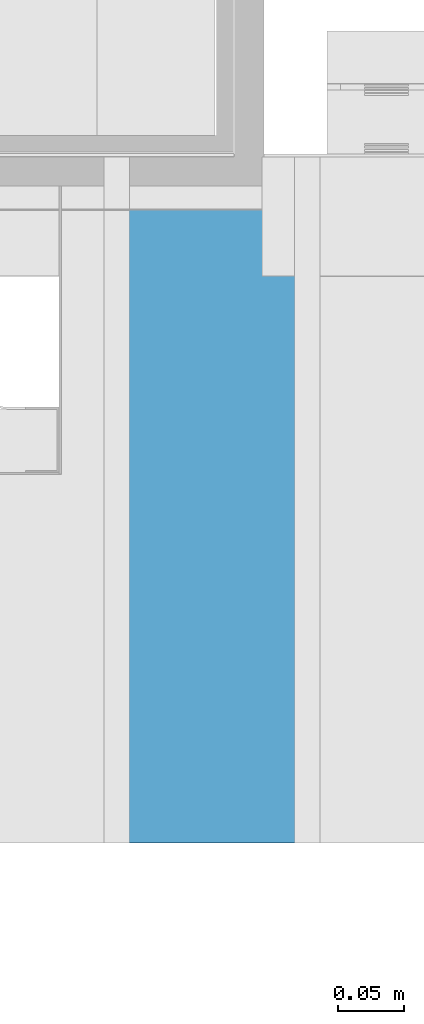
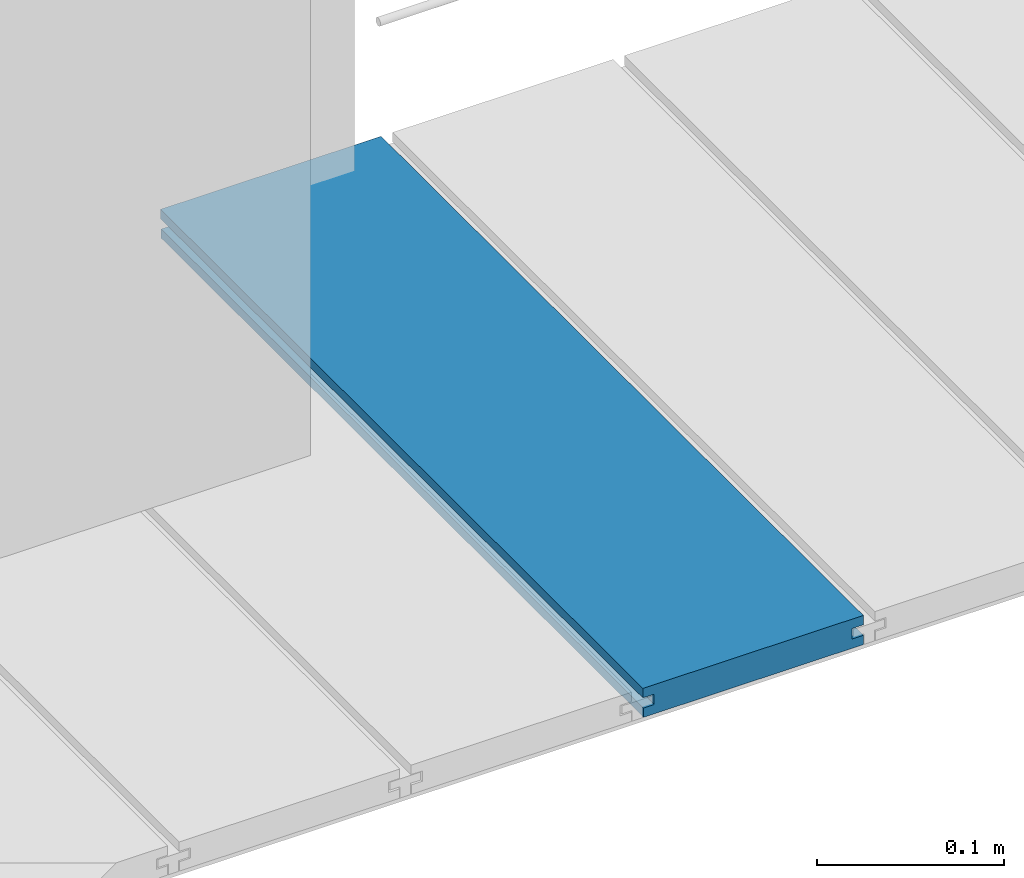
# One storey, part 19 of 33: 1 wall.
"""IFC4 building model written with IfcOpenShell, lengths in feet."""

from ifc_helpers import new_model, entity, si_unit, converted_unit, derived_unit, direction, frame, origin, place, context, subcontext, project, spatial, material, type_object, element, save


model = new_model("IFC4")

# Units and contexts
model_context = context("Model", 3, precision=0.0001, world=origin(), true_north=direction((6.12303176911189e-17, 1.0)))
body_context = subcontext(model_context, "Body", "Model", "MODEL_VIEW")
ifc_project = project(units=[converted_unit("LENGTHUNIT", "FOOT", entity("IfcRatioMeasure", 0.3048), si_unit("LENGTHUNIT", "METRE"), dimensions=[1, 0, 0, 0, 0, 0, 0]), converted_unit("AREAUNIT", "SQUARE FOOT", entity("IfcRatioMeasure", 0.09290304), si_unit("AREAUNIT", "SQUARE_METRE"), dimensions=[2, 0, 0, 0, 0, 0, 0]), converted_unit("VOLUMEUNIT", "CUBIC FOOT", entity("IfcRatioMeasure", 0.028316846592), si_unit("VOLUMEUNIT", "CUBIC_METRE"), dimensions=[3, 0, 0, 0, 0, 0, 0]), converted_unit("PLANEANGLEUNIT", "DEGREE", entity("IfcRatioMeasure", 0.0174532925199433), si_unit("PLANEANGLEUNIT", "RADIAN"), dimensions=[0, 0, 0, 0, 0, 0, 0]), si_unit("MASSUNIT", "GRAM", prefix="KILO"), derived_unit("MASSDENSITYUNIT", [(si_unit("MASSUNIT", "GRAM", prefix="KILO"), 1), (si_unit("LENGTHUNIT", "METRE"), -3)]), derived_unit("MOMENTOFINERTIAUNIT", [(si_unit("LENGTHUNIT", "METRE"), 4)]), si_unit("TIMEUNIT", "SECOND"), si_unit("FREQUENCYUNIT", "HERTZ"), si_unit("THERMODYNAMICTEMPERATUREUNIT", "DEGREE_CELSIUS"), derived_unit("THERMALTRANSMITTANCEUNIT", [(si_unit("MASSUNIT", "GRAM", prefix="KILO"), 1), (si_unit("THERMODYNAMICTEMPERATUREUNIT", "KELVIN"), -1), (si_unit("TIMEUNIT", "SECOND"), -3)]), derived_unit("VOLUMETRICFLOWRATEUNIT", [(si_unit("LENGTHUNIT", "METRE"), 3), (si_unit("TIMEUNIT", "SECOND"), -1)]), si_unit("ELECTRICCURRENTUNIT", "AMPERE"), si_unit("ELECTRICVOLTAGEUNIT", "VOLT"), si_unit("POWERUNIT", "WATT"), si_unit("FORCEUNIT", "NEWTON"), si_unit("ILLUMINANCEUNIT", "LUX"), si_unit("LUMINOUSFLUXUNIT", "LUMEN"), si_unit("LUMINOUSINTENSITYUNIT", "CANDELA"), derived_unit("USERDEFINED", [(si_unit("MASSUNIT", "GRAM", prefix="KILO"), -1), (si_unit("LENGTHUNIT", "METRE"), -2), (si_unit("TIMEUNIT", "SECOND"), 3), (si_unit("LUMINOUSFLUXUNIT", "LUMEN"), 1)]), derived_unit("LINEARVELOCITYUNIT", [(si_unit("LENGTHUNIT", "METRE"), 1), (si_unit("TIMEUNIT", "SECOND"), -1)]), si_unit("PRESSUREUNIT", "PASCAL"), derived_unit("USERDEFINED", [(si_unit("LENGTHUNIT", "METRE"), -2), (si_unit("MASSUNIT", "GRAM", prefix="KILO"), 1), (si_unit("TIMEUNIT", "SECOND"), -2)]), derived_unit("LINEARFORCEUNIT", [(si_unit("MASSUNIT", "GRAM", prefix="KILO"), 1), (si_unit("LENGTHUNIT", "METRE"), 1), (si_unit("TIMEUNIT", "SECOND"), -2), (si_unit("LENGTHUNIT", "METRE"), -1)]), derived_unit("PLANARFORCEUNIT", [(si_unit("MASSUNIT", "GRAM", prefix="KILO"), 1), (si_unit("LENGTHUNIT", "METRE"), 1), (si_unit("TIMEUNIT", "SECOND"), -2), (si_unit("LENGTHUNIT", "METRE"), -2)])], contexts=[model_context])

# Site, building, storey
site_placement = place(None, origin())
site = spatial("IfcSite", under=ifc_project, at=site_placement, CompositionType="ELEMENT")
building_placement = place(site_placement, origin())
building = spatial("IfcBuilding", under=site, at=building_placement, CompositionType="ELEMENT")
storey_placement = place(building_placement, frame((0.0, 0.0, 10.0)))
storey = spatial("IfcBuildingStorey", under=building, at=storey_placement, Name="2ND FLOOR", CompositionType="ELEMENT", Elevation=10.0000000000002)

# Wall
ifc_material = material(Name="COMPOSITE DECKING W/ HIDDEN FASTENERS", Category="Materials")
wall_type = type_object("IfcWallType", Name="Generic Models 661:Generic Models 1", PredefinedType="NOTDEFINED", material=ifc_material)
wall_placement = place(storey_placement, frame((1492.00118914657, 3.0461139299927, 0.682902157150133), z_axis=(0.0, 0.0, 1.0), x_axis=(0.0, 1.0, 0.0)))
cartesian_point_1 = entity("IfcCartesianPoint", [1.69226081335874, -0.446740923891412, 0.0])
vertex_point_1 = entity("IfcVertexPoint", cartesian_point_1)
cartesian_point_2 = entity("IfcCartesianPoint", [1.69226081335875, -0.00132475379450625, 0.0])
vertex_point_2 = entity("IfcVertexPoint", cartesian_point_2)
ifc_direction_1 = entity("IfcDirection", [0.0, 1.0, 0.0])
edge_curve_1 = entity("IfcEdgeCurve", vertex_point_1, vertex_point_2, entity("IfcTrimmedCurve", entity("IfcLine", cartesian_point_1, entity("IfcVector", ifc_direction_1, 1.0)), [cartesian_point_1], [cartesian_point_2], True, "CARTESIAN"), True)
cartesian_point_3 = entity("IfcCartesianPoint", [1.69226081335875, -0.00132475379450625, 0.0198779960861479])
vertex_point_3 = entity("IfcVertexPoint", cartesian_point_3)
ifc_direction_2 = entity("IfcDirection", [0.0, 0.0, 1.0])
edge_curve_2 = entity("IfcEdgeCurve", vertex_point_2, vertex_point_3, entity("IfcTrimmedCurve", entity("IfcLine", cartesian_point_2, entity("IfcVector", ifc_direction_2, 1.0)), [cartesian_point_2], [cartesian_point_3], True, "CARTESIAN"), True)
cartesian_point_4 = entity("IfcCartesianPoint", [1.69226081335875, -0.0228400010807945, 0.0198779960861479])
vertex_point_4 = entity("IfcVertexPoint", cartesian_point_4)
ifc_direction_3 = entity("IfcDirection", [0.0, -1.0, 0.0])
edge_curve_3 = entity("IfcEdgeCurve", vertex_point_3, vertex_point_4, entity("IfcTrimmedCurve", entity("IfcLine", cartesian_point_3, entity("IfcVector", ifc_direction_3, 1.0)), [cartesian_point_3], [cartesian_point_4], True, "CARTESIAN"), True)
cartesian_point_5 = entity("IfcCartesianPoint", [1.69226081335875, -0.0228400010807945, 0.0422987663426522])
vertex_point_5 = entity("IfcVertexPoint", cartesian_point_5)
edge_curve_4 = entity("IfcEdgeCurve", vertex_point_4, vertex_point_5, entity("IfcTrimmedCurve", entity("IfcLine", cartesian_point_4, entity("IfcVector", ifc_direction_2, 1.0)), [cartesian_point_4], [cartesian_point_5], True, "CARTESIAN"), True)
cartesian_point_6 = entity("IfcCartesianPoint", [1.69226081335875, 0.0, 0.0422987663426522])
vertex_point_6 = entity("IfcVertexPoint", cartesian_point_6)
edge_curve_5 = entity("IfcEdgeCurve", vertex_point_5, vertex_point_6, entity("IfcTrimmedCurve", entity("IfcLine", cartesian_point_5, entity("IfcVector", ifc_direction_1, 1.0)), [cartesian_point_5], [cartesian_point_6], True, "CARTESIAN"), True)
cartesian_point_7 = entity("IfcCartesianPoint", [1.69226081335875, 0.0, 0.0625000000000551])
vertex_point_7 = entity("IfcVertexPoint", cartesian_point_7)
edge_curve_6 = entity("IfcEdgeCurve", vertex_point_6, vertex_point_7, entity("IfcTrimmedCurve", entity("IfcLine", cartesian_point_6, entity("IfcVector", ifc_direction_2, 1.0)), [cartesian_point_6], [cartesian_point_7], True, "CARTESIAN"), True)
cartesian_point_8 = entity("IfcCartesianPoint", [1.69226081335874, -0.446740923891639, 0.0625])
vertex_point_8 = entity("IfcVertexPoint", cartesian_point_8)
edge_curve_7 = entity("IfcEdgeCurve", vertex_point_7, vertex_point_8, entity("IfcTrimmedCurve", entity("IfcLine", cartesian_point_7, entity("IfcVector", ifc_direction_3, 1.0)), [cartesian_point_7], [cartesian_point_8], True, "CARTESIAN"), True)
cartesian_point_9 = entity("IfcCartesianPoint", [1.69226081335874, -0.446740923891639, 0.0422987663426522])
vertex_point_9 = entity("IfcVertexPoint", cartesian_point_9)
ifc_direction_4 = entity("IfcDirection", [0.0, 0.0, -1.0])
edge_curve_8 = entity("IfcEdgeCurve", vertex_point_8, vertex_point_9, entity("IfcTrimmedCurve", entity("IfcLine", cartesian_point_8, entity("IfcVector", ifc_direction_4, 1.0)), [cartesian_point_8], [cartesian_point_9], True, "CARTESIAN"), True)
cartesian_point_10 = entity("IfcCartesianPoint", [1.69226081335874, -0.423900922810617, 0.0422987663426522])
vertex_point_10 = entity("IfcVertexPoint", cartesian_point_10)
edge_curve_9 = entity("IfcEdgeCurve", vertex_point_9, vertex_point_10, entity("IfcTrimmedCurve", entity("IfcLine", cartesian_point_9, entity("IfcVector", ifc_direction_1, 1.0)), [cartesian_point_9], [cartesian_point_10], True, "CARTESIAN"), True)
cartesian_point_11 = entity("IfcCartesianPoint", [1.69226081335874, -0.423900922810617, 0.0198779960861479])
vertex_point_11 = entity("IfcVertexPoint", cartesian_point_11)
edge_curve_10 = entity("IfcEdgeCurve", vertex_point_10, vertex_point_11, entity("IfcTrimmedCurve", entity("IfcLine", cartesian_point_10, entity("IfcVector", ifc_direction_4, 1.0)), [cartesian_point_10], [cartesian_point_11], True, "CARTESIAN"), True)
cartesian_point_12 = entity("IfcCartesianPoint", [1.69226081335874, -0.446740923891412, 0.0198779960861479])
vertex_point_12 = entity("IfcVertexPoint", cartesian_point_12)
edge_curve_11 = entity("IfcEdgeCurve", vertex_point_11, vertex_point_12, entity("IfcTrimmedCurve", entity("IfcLine", cartesian_point_11, entity("IfcVector", ifc_direction_3, 1.0)), [cartesian_point_11], [cartesian_point_12], True, "CARTESIAN"), True)
edge_curve_12 = entity("IfcEdgeCurve", vertex_point_12, vertex_point_1, entity("IfcTrimmedCurve", entity("IfcLine", cartesian_point_12, entity("IfcVector", ifc_direction_4, 1.0)), [cartesian_point_12], [cartesian_point_1], True, "CARTESIAN"), True)
ifc_direction_5 = entity("IfcDirection", [1.0, 0.0, 0.0])
cartesian_point_13 = entity("IfcCartesianPoint", [0.0, -0.446740923891412, 0.0])
vertex_point_13 = entity("IfcVertexPoint", cartesian_point_13)
cartesian_point_14 = entity("IfcCartesianPoint", [0.0, -0.446740923891412, 0.0198779960861479])
vertex_point_14 = entity("IfcVertexPoint", cartesian_point_14)
edge_curve_13 = entity("IfcEdgeCurve", vertex_point_13, vertex_point_14, entity("IfcTrimmedCurve", entity("IfcLine", cartesian_point_13, entity("IfcVector", ifc_direction_2, 1.0)), [cartesian_point_13], [cartesian_point_14], True, "CARTESIAN"), True)
cartesian_point_15 = entity("IfcCartesianPoint", [0.0, -0.423900922810617, 0.0198779960861479])
vertex_point_15 = entity("IfcVertexPoint", cartesian_point_15)
edge_curve_14 = entity("IfcEdgeCurve", vertex_point_14, vertex_point_15, entity("IfcTrimmedCurve", entity("IfcLine", cartesian_point_14, entity("IfcVector", ifc_direction_1, 1.0)), [cartesian_point_14], [cartesian_point_15], True, "CARTESIAN"), True)
cartesian_point_16 = entity("IfcCartesianPoint", [0.0, -0.423900922810617, 0.0422987663426522])
vertex_point_16 = entity("IfcVertexPoint", cartesian_point_16)
edge_curve_15 = entity("IfcEdgeCurve", vertex_point_15, vertex_point_16, entity("IfcTrimmedCurve", entity("IfcLine", cartesian_point_15, entity("IfcVector", ifc_direction_2, 1.0)), [cartesian_point_15], [cartesian_point_16], True, "CARTESIAN"), True)
cartesian_point_17 = entity("IfcCartesianPoint", [0.0, -0.446740923891639, 0.0422987663426522])
vertex_point_17 = entity("IfcVertexPoint", cartesian_point_17)
edge_curve_16 = entity("IfcEdgeCurve", vertex_point_16, vertex_point_17, entity("IfcTrimmedCurve", entity("IfcLine", cartesian_point_16, entity("IfcVector", ifc_direction_3, 1.0)), [cartesian_point_16], [cartesian_point_17], True, "CARTESIAN"), True)
cartesian_point_18 = entity("IfcCartesianPoint", [0.0, -0.446740923891639, 0.0625])
vertex_point_18 = entity("IfcVertexPoint", cartesian_point_18)
edge_curve_17 = entity("IfcEdgeCurve", vertex_point_17, vertex_point_18, entity("IfcTrimmedCurve", entity("IfcLine", cartesian_point_17, entity("IfcVector", ifc_direction_2, 1.0)), [cartesian_point_17], [cartesian_point_18], True, "CARTESIAN"), True)
cartesian_point_19 = entity("IfcCartesianPoint", [0.0, 0.0, 0.0625000000000551])
vertex_point_19 = entity("IfcVertexPoint", cartesian_point_19)
edge_curve_18 = entity("IfcEdgeCurve", vertex_point_18, vertex_point_19, entity("IfcTrimmedCurve", entity("IfcLine", cartesian_point_18, entity("IfcVector", ifc_direction_1, 1.0)), [cartesian_point_18], [cartesian_point_19], True, "CARTESIAN"), True)
cartesian_point_20 = entity("IfcCartesianPoint", [0.0, 0.0, 0.0422987663426522])
vertex_point_20 = entity("IfcVertexPoint", cartesian_point_20)
edge_curve_19 = entity("IfcEdgeCurve", vertex_point_19, vertex_point_20, entity("IfcTrimmedCurve", entity("IfcLine", cartesian_point_19, entity("IfcVector", ifc_direction_4, 1.0)), [cartesian_point_19], [cartesian_point_20], True, "CARTESIAN"), True)
cartesian_point_21 = entity("IfcCartesianPoint", [0.0, -0.0228400010807945, 0.0422987663426522])
vertex_point_21 = entity("IfcVertexPoint", cartesian_point_21)
edge_curve_20 = entity("IfcEdgeCurve", vertex_point_20, vertex_point_21, entity("IfcTrimmedCurve", entity("IfcLine", cartesian_point_20, entity("IfcVector", ifc_direction_3, 1.0)), [cartesian_point_20], [cartesian_point_21], True, "CARTESIAN"), True)
cartesian_point_22 = entity("IfcCartesianPoint", [0.0, -0.0228400010807945, 0.0198779960861479])
vertex_point_22 = entity("IfcVertexPoint", cartesian_point_22)
edge_curve_21 = entity("IfcEdgeCurve", vertex_point_21, vertex_point_22, entity("IfcTrimmedCurve", entity("IfcLine", cartesian_point_21, entity("IfcVector", ifc_direction_4, 1.0)), [cartesian_point_21], [cartesian_point_22], True, "CARTESIAN"), True)
cartesian_point_23 = entity("IfcCartesianPoint", [0.0, -0.00132475379450625, 0.0198779960861479])
vertex_point_23 = entity("IfcVertexPoint", cartesian_point_23)
edge_curve_22 = entity("IfcEdgeCurve", vertex_point_22, vertex_point_23, entity("IfcTrimmedCurve", entity("IfcLine", cartesian_point_22, entity("IfcVector", ifc_direction_1, 1.0)), [cartesian_point_22], [cartesian_point_23], True, "CARTESIAN"), True)
cartesian_point_24 = entity("IfcCartesianPoint", [0.0, -0.00132475379450625, 0.0])
vertex_point_24 = entity("IfcVertexPoint", cartesian_point_24)
edge_curve_23 = entity("IfcEdgeCurve", vertex_point_23, vertex_point_24, entity("IfcTrimmedCurve", entity("IfcLine", cartesian_point_23, entity("IfcVector", ifc_direction_4, 1.0)), [cartesian_point_23], [cartesian_point_24], True, "CARTESIAN"), True)
edge_curve_24 = entity("IfcEdgeCurve", vertex_point_24, vertex_point_13, entity("IfcTrimmedCurve", entity("IfcLine", cartesian_point_24, entity("IfcVector", ifc_direction_3, 1.0)), [cartesian_point_24], [cartesian_point_13], True, "CARTESIAN"), True)
ifc_direction_6 = entity("IfcDirection", [-1.0, 0.0, 0.0])
edge_curve_25 = entity("IfcEdgeCurve", vertex_point_13, vertex_point_1, entity("IfcTrimmedCurve", entity("IfcLine", cartesian_point_13, entity("IfcVector", ifc_direction_5, 1.0)), [cartesian_point_13], [cartesian_point_1], True, "CARTESIAN"), True)
edge_curve_26 = entity("IfcEdgeCurve", vertex_point_12, vertex_point_14, entity("IfcTrimmedCurve", entity("IfcLine", cartesian_point_14, entity("IfcVector", ifc_direction_6, 1.0)), [cartesian_point_12], [cartesian_point_14], True, "CARTESIAN"), True)
edge_curve_27 = entity("IfcEdgeCurve", vertex_point_18, vertex_point_8, entity("IfcTrimmedCurve", entity("IfcLine", cartesian_point_18, entity("IfcVector", ifc_direction_5, 1.0)), [cartesian_point_18], [cartesian_point_8], True, "CARTESIAN"), True)
edge_curve_28 = entity("IfcEdgeCurve", vertex_point_7, vertex_point_19, entity("IfcTrimmedCurve", entity("IfcLine", cartesian_point_19, entity("IfcVector", ifc_direction_6, 1.0)), [cartesian_point_7], [cartesian_point_19], True, "CARTESIAN"), True)
edge_curve_29 = entity("IfcEdgeCurve", vertex_point_6, vertex_point_20, entity("IfcTrimmedCurve", entity("IfcLine", cartesian_point_20, entity("IfcVector", ifc_direction_6, 1.0)), [cartesian_point_6], [cartesian_point_20], True, "CARTESIAN"), True)
edge_curve_30 = entity("IfcEdgeCurve", vertex_point_24, vertex_point_2, entity("IfcTrimmedCurve", entity("IfcLine", cartesian_point_24, entity("IfcVector", ifc_direction_5, 1.0)), [cartesian_point_24], [cartesian_point_2], True, "CARTESIAN"), True)
edge_curve_31 = entity("IfcEdgeCurve", vertex_point_17, vertex_point_9, entity("IfcTrimmedCurve", entity("IfcLine", cartesian_point_17, entity("IfcVector", ifc_direction_5, 1.0)), [cartesian_point_17], [cartesian_point_9], True, "CARTESIAN"), True)
edge_curve_32 = entity("IfcEdgeCurve", vertex_point_5, vertex_point_21, entity("IfcTrimmedCurve", entity("IfcLine", cartesian_point_21, entity("IfcVector", ifc_direction_6, 1.0)), [cartesian_point_5], [cartesian_point_21], True, "CARTESIAN"), True)
edge_curve_33 = entity("IfcEdgeCurve", vertex_point_4, vertex_point_22, entity("IfcTrimmedCurve", entity("IfcLine", cartesian_point_22, entity("IfcVector", ifc_direction_6, 1.0)), [cartesian_point_4], [cartesian_point_22], True, "CARTESIAN"), True)
edge_curve_34 = entity("IfcEdgeCurve", vertex_point_3, vertex_point_23, entity("IfcTrimmedCurve", entity("IfcLine", cartesian_point_23, entity("IfcVector", ifc_direction_6, 1.0)), [cartesian_point_3], [cartesian_point_23], True, "CARTESIAN"), True)
edge_curve_35 = entity("IfcEdgeCurve", vertex_point_11, vertex_point_15, entity("IfcTrimmedCurve", entity("IfcLine", cartesian_point_15, entity("IfcVector", ifc_direction_6, 1.0)), [cartesian_point_11], [cartesian_point_15], True, "CARTESIAN"), True)
edge_curve_36 = entity("IfcEdgeCurve", vertex_point_10, vertex_point_16, entity("IfcTrimmedCurve", entity("IfcLine", cartesian_point_16, entity("IfcVector", ifc_direction_6, 1.0)), [cartesian_point_10], [cartesian_point_16], True, "CARTESIAN"), True)
element("IfcWall", 1, at=wall_placement, inside=storey, type_object=wall_type, material=ifc_material, Name="Generic Models 661:Generic Models 1", ObjectType="Generic Models 661:Generic Models 1", PredefinedType="NOTDEFINED", context=body_context, shape_type="AdvancedBrep", body=[
    entity("IfcAdvancedBrep", entity("IfcClosedShell", [entity("IfcAdvancedFace", [entity("IfcFaceOuterBound", entity("IfcEdgeLoop", [entity("IfcOrientedEdge", None, None, edge_curve_1, True), entity("IfcOrientedEdge", None, None, edge_curve_2, True), entity("IfcOrientedEdge", None, None, edge_curve_3, True), entity("IfcOrientedEdge", None, None, edge_curve_4, True), entity("IfcOrientedEdge", None, None, edge_curve_5, True), entity("IfcOrientedEdge", None, None, edge_curve_6, True), entity("IfcOrientedEdge", None, None, edge_curve_7, True), entity("IfcOrientedEdge", None, None, edge_curve_8, True), entity("IfcOrientedEdge", None, None, edge_curve_9, True), entity("IfcOrientedEdge", None, None, edge_curve_10, True), entity("IfcOrientedEdge", None, None, edge_curve_11, True), entity("IfcOrientedEdge", None, None, edge_curve_12, True)]), True)], entity("IfcPlane", entity("IfcAxis2Placement3D", entity("IfcCartesianPoint", [1.69226081335874, -0.446740923891412, -0.0208333333328241]), ifc_direction_5, ifc_direction_4)), True), entity("IfcAdvancedFace", [entity("IfcFaceOuterBound", entity("IfcEdgeLoop", [entity("IfcOrientedEdge", None, None, edge_curve_13, True), entity("IfcOrientedEdge", None, None, edge_curve_14, True), entity("IfcOrientedEdge", None, None, edge_curve_15, True), entity("IfcOrientedEdge", None, None, edge_curve_16, True), entity("IfcOrientedEdge", None, None, edge_curve_17, True), entity("IfcOrientedEdge", None, None, edge_curve_18, True), entity("IfcOrientedEdge", None, None, edge_curve_19, True), entity("IfcOrientedEdge", None, None, edge_curve_20, True), entity("IfcOrientedEdge", None, None, edge_curve_21, True), entity("IfcOrientedEdge", None, None, edge_curve_22, True), entity("IfcOrientedEdge", None, None, edge_curve_23, True), entity("IfcOrientedEdge", None, None, edge_curve_24, True)]), True)], entity("IfcPlane", entity("IfcAxis2Placement3D", entity("IfcCartesianPoint", [0.0, -0.446740923891412, -0.0208333333328241]), ifc_direction_6, ifc_direction_2)), True), entity("IfcAdvancedFace", [entity("IfcFaceOuterBound", entity("IfcEdgeLoop", [entity("IfcOrientedEdge", None, None, edge_curve_13, False), entity("IfcOrientedEdge", None, None, edge_curve_25, True), entity("IfcOrientedEdge", None, None, edge_curve_12, False), entity("IfcOrientedEdge", None, None, edge_curve_26, True)]), True)], entity("IfcPlane", entity("IfcAxis2Placement3D", cartesian_point_13, ifc_direction_3, ifc_direction_5)), True), entity("IfcAdvancedFace", [entity("IfcFaceOuterBound", entity("IfcEdgeLoop", [entity("IfcOrientedEdge", None, None, edge_curve_18, False), entity("IfcOrientedEdge", None, None, edge_curve_27, True), entity("IfcOrientedEdge", None, None, edge_curve_7, False), entity("IfcOrientedEdge", None, None, edge_curve_28, True)]), True)], entity("IfcPlane", entity("IfcAxis2Placement3D", cartesian_point_18, ifc_direction_2, ifc_direction_5)), True), entity("IfcAdvancedFace", [entity("IfcFaceOuterBound", entity("IfcEdgeLoop", [entity("IfcOrientedEdge", None, None, edge_curve_19, False), entity("IfcOrientedEdge", None, None, edge_curve_28, False), entity("IfcOrientedEdge", None, None, edge_curve_6, False), entity("IfcOrientedEdge", None, None, edge_curve_29, True)]), True)], entity("IfcPlane", entity("IfcAxis2Placement3D", cartesian_point_19, ifc_direction_1, ifc_direction_5)), True), entity("IfcAdvancedFace", [entity("IfcFaceOuterBound", entity("IfcEdgeLoop", [entity("IfcOrientedEdge", None, None, edge_curve_24, False), entity("IfcOrientedEdge", None, None, edge_curve_30, True), entity("IfcOrientedEdge", None, None, edge_curve_1, False), entity("IfcOrientedEdge", None, None, edge_curve_25, False)]), True)], entity("IfcPlane", entity("IfcAxis2Placement3D", cartesian_point_24, ifc_direction_4, ifc_direction_5)), True), entity("IfcAdvancedFace", [entity("IfcFaceOuterBound", entity("IfcEdgeLoop", [entity("IfcOrientedEdge", None, None, edge_curve_17, False), entity("IfcOrientedEdge", None, None, edge_curve_31, True), entity("IfcOrientedEdge", None, None, edge_curve_8, False), entity("IfcOrientedEdge", None, None, edge_curve_27, False)]), True)], entity("IfcPlane", entity("IfcAxis2Placement3D", cartesian_point_17, ifc_direction_3, ifc_direction_5)), True), entity("IfcAdvancedFace", [entity("IfcFaceOuterBound", entity("IfcEdgeLoop", [entity("IfcOrientedEdge", None, None, edge_curve_20, False), entity("IfcOrientedEdge", None, None, edge_curve_29, False), entity("IfcOrientedEdge", None, None, edge_curve_5, False), entity("IfcOrientedEdge", None, None, edge_curve_32, True)]), True)], entity("IfcPlane", entity("IfcAxis2Placement3D", cartesian_point_20, ifc_direction_4, ifc_direction_5)), True), entity("IfcAdvancedFace", [entity("IfcFaceOuterBound", entity("IfcEdgeLoop", [entity("IfcOrientedEdge", None, None, edge_curve_21, False), entity("IfcOrientedEdge", None, None, edge_curve_32, False), entity("IfcOrientedEdge", None, None, edge_curve_4, False), entity("IfcOrientedEdge", None, None, edge_curve_33, True)]), True)], entity("IfcPlane", entity("IfcAxis2Placement3D", cartesian_point_21, ifc_direction_1, ifc_direction_5)), True), entity("IfcAdvancedFace", [entity("IfcFaceOuterBound", entity("IfcEdgeLoop", [entity("IfcOrientedEdge", None, None, edge_curve_22, False), entity("IfcOrientedEdge", None, None, edge_curve_33, False), entity("IfcOrientedEdge", None, None, edge_curve_3, False), entity("IfcOrientedEdge", None, None, edge_curve_34, True)]), True)], entity("IfcPlane", entity("IfcAxis2Placement3D", cartesian_point_22, ifc_direction_2, ifc_direction_5)), True), entity("IfcAdvancedFace", [entity("IfcFaceOuterBound", entity("IfcEdgeLoop", [entity("IfcOrientedEdge", None, None, edge_curve_23, False), entity("IfcOrientedEdge", None, None, edge_curve_34, False), entity("IfcOrientedEdge", None, None, edge_curve_2, False), entity("IfcOrientedEdge", None, None, edge_curve_30, False)]), True)], entity("IfcPlane", entity("IfcAxis2Placement3D", cartesian_point_23, ifc_direction_1, ifc_direction_5)), True), entity("IfcAdvancedFace", [entity("IfcFaceOuterBound", entity("IfcEdgeLoop", [entity("IfcOrientedEdge", None, None, edge_curve_14, False), entity("IfcOrientedEdge", None, None, edge_curve_26, False), entity("IfcOrientedEdge", None, None, edge_curve_11, False), entity("IfcOrientedEdge", None, None, edge_curve_35, True)]), True)], entity("IfcPlane", entity("IfcAxis2Placement3D", cartesian_point_14, ifc_direction_2, ifc_direction_5)), True), entity("IfcAdvancedFace", [entity("IfcFaceOuterBound", entity("IfcEdgeLoop", [entity("IfcOrientedEdge", None, None, edge_curve_15, False), entity("IfcOrientedEdge", None, None, edge_curve_35, False), entity("IfcOrientedEdge", None, None, edge_curve_10, False), entity("IfcOrientedEdge", None, None, edge_curve_36, True)]), True)], entity("IfcPlane", entity("IfcAxis2Placement3D", cartesian_point_15, ifc_direction_3, ifc_direction_5)), True), entity("IfcAdvancedFace", [entity("IfcFaceOuterBound", entity("IfcEdgeLoop", [entity("IfcOrientedEdge", None, None, edge_curve_16, False), entity("IfcOrientedEdge", None, None, edge_curve_36, False), entity("IfcOrientedEdge", None, None, edge_curve_9, False), entity("IfcOrientedEdge", None, None, edge_curve_31, False)]), True)], entity("IfcPlane", entity("IfcAxis2Placement3D", cartesian_point_16, ifc_direction_4, ifc_direction_5)), True)])),
])

save(model, "model.ifc")
